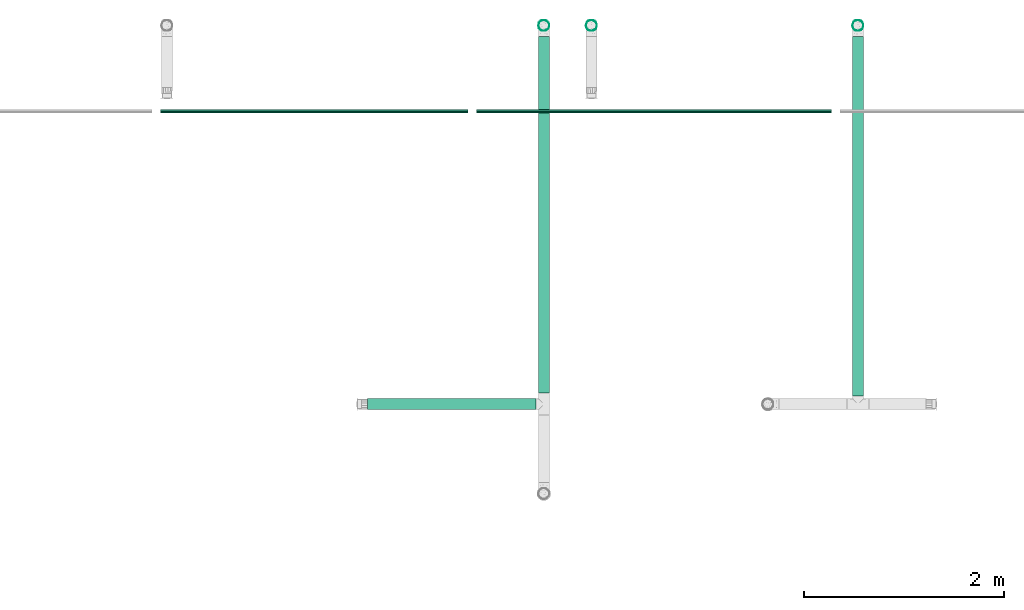
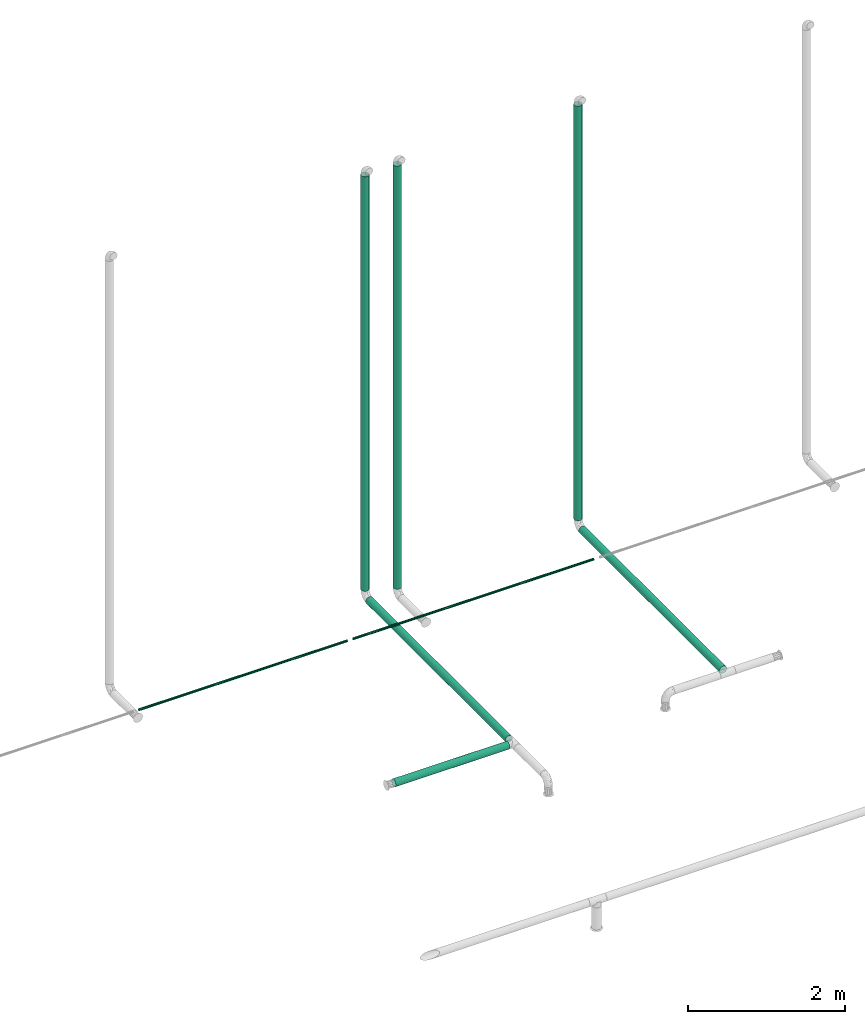
# One storey, part 18 of 123: 8 flow segments.
"""IFC2X3 building model written with IfcOpenShell, lengths in millimetres."""

from ifc_helpers import new_model, entity, si_unit, converted_unit, derived_unit, direction, frame, origin_with_axes, origin_2d_with_axis, place, context, subcontext, project, spatial, hollow_circle, extrude, source, transform, mapped, material, layer, layer_set, layer_usage, type_object, element, save


model = new_model("IFC2X3")

# Units and contexts
model_context = context("Model", 3, precision=1e-05, world=origin_with_axes(), true_north=direction((0.0, 1.0)))
body_context = subcontext(model_context, "Body", "Model", "MODEL_VIEW")
ifc_project = project(units=[si_unit("AREAUNIT", "SQUARE_METRE"), si_unit("VOLUMEUNIT", "CUBIC_METRE", prefix="DECI"), si_unit("TIMEUNIT", "SECOND"), si_unit("THERMODYNAMICTEMPERATUREUNIT", "DEGREE_CELSIUS"), si_unit("PRESSUREUNIT", "PASCAL"), si_unit("MASSUNIT", "GRAM", prefix="KILO"), si_unit("LENGTHUNIT", "METRE", prefix="MILLI"), si_unit("POWERUNIT", "WATT"), si_unit("ELECTRICCURRENTUNIT", "AMPERE"), si_unit("ELECTRICVOLTAGEUNIT", "VOLT"), derived_unit("VOLUMETRICFLOWRATEUNIT", [(si_unit("VOLUMEUNIT", "CUBIC_METRE", prefix="DECI"), 1), (si_unit("TIMEUNIT", "SECOND"), -1)]), derived_unit("LINEARVELOCITYUNIT", [(si_unit("LENGTHUNIT", "METRE"), 1), (si_unit("TIMEUNIT", "SECOND"), -1)]), derived_unit("MASSDENSITYUNIT", [(si_unit("MASSUNIT", "GRAM", prefix="KILO"), 1), (si_unit("VOLUMEUNIT", "CUBIC_METRE"), -1)]), converted_unit("PLANEANGLEUNIT", "DEGREE", entity("IfcRatioMeasure", 0.01745), si_unit("PLANEANGLEUNIT", "RADIAN"), dimensions=[0, 0, 0, 0, 0, 0, 0])], contexts=[model_context])

# Site, building, storey
site_placement = place(None, origin_with_axes())
site = spatial("IfcSite", under=ifc_project, at=site_placement, CompositionType="ELEMENT")
building_placement = place(site_placement, origin_with_axes())
building = spatial("IfcBuilding", under=site, at=building_placement, Name="mc-building", CompositionType="ELEMENT")
storey_placement = place(building_placement, origin_with_axes())
storey = spatial("IfcBuildingStorey", under=building, at=storey_placement, Name="1. Korrus", CompositionType="ELEMENT", Elevation=0.0)

# Flow segments
ifc_material_1 = material(Name="FZ1")
ifc_layer_1 = layer(ifc_material_1, 0.0)
ifc_layer_set_1 = layer_set([ifc_layer_1], Name="FZ1")
ifc_layer_usage_1 = layer_usage(ifc_layer_set_1, "AXIS1", "POSITIVE", 0.0)
duct_segment_type = type_object("IfcDuctSegmentType", PredefinedType="RIGIDSEGMENT")
shared_shape_1 = source(origin_with_axes(), body_context, "Body", "SweptSolid", [
    extrude(hollow_circle(Radius=55.0, WallThickness=2.0, at=origin_2d_with_axis()), frame((0.0, 0.0, 0.0), z_axis=(1.0, 0.0, 0.0), x_axis=(0.0, 1.0, 0.0)), (0.0, 0.0, 1.0), 3565.9),
])
flow_segment_1_placement = place(storey_placement, frame((29888.82784, 13553.57591, 2435.0), z_axis=(0.0, 0.0, 1.0), x_axis=(0.0, -1.0, 0.0)))
element("IfcFlowSegment", 1, at=flow_segment_1_placement, inside=storey, type_object=duct_segment_type, material=ifc_layer_usage_1, context=body_context, shape_type="MappedRepresentation", body=[
    mapped(shared_shape_1, transform((0.0, 0.0, 0.0), scale=1.0)),
])
shared_shape_2 = source(origin_with_axes(), body_context, "Body", "SweptSolid", [
    extrude(hollow_circle(Radius=55.0, WallThickness=2.0, at=origin_2d_with_axis()), frame((0.0, 0.0, 0.0), z_axis=(1.0, 0.0, 0.0), x_axis=(0.0, 1.0, 0.0)), (0.0, 0.0, 1.0), 6595.0),
])
flow_segment_2_placement = place(storey_placement, frame((30364.56773, 13663.57591, 2410.0), z_axis=(0.0, -1.0, 0.0), x_axis=(0.0, 0.0, 1.0)))
element("IfcFlowSegment", 2, at=flow_segment_2_placement, inside=storey, type_object=duct_segment_type, material=ifc_layer_usage_1, context=body_context, shape_type="MappedRepresentation", body=[
    mapped(shared_shape_2, transform((0.0, 0.0, 0.0), scale=1.0)),
])
ifc_material_2 = material(Name="Steel")
ifc_layer_2 = layer(ifc_material_2, 0.0)
ifc_layer_set_2 = layer_set([ifc_layer_2], Name="Steel")
ifc_layer_usage_2 = layer_usage(ifc_layer_set_2, "AXIS1", "POSITIVE", 0.0)
pipe_segment_type = type_object("IfcPipeSegmentType", PredefinedType="RIGIDSEGMENT")
shared_shape_3 = source(origin_with_axes(), body_context, "Body", "SweptSolid", [
    extrude(hollow_circle(Radius=17.5, WallThickness=2.0, at=origin_2d_with_axis()), frame((0.0, 0.0, 0.0), z_axis=(1.0, 0.0, 0.0), x_axis=(0.0, 1.0, 0.0)), (0.0, 0.0, 1.0), 3075.4),
])
flow_segment_3_placement = place(storey_placement, frame((26057.00462, 12807.91734, 2520.89768), z_axis=(0.0, 0.0, 1.0), x_axis=(1.0, 0.0, 0.0)))
element("IfcFlowSegment", 3, at=flow_segment_3_placement, inside=storey, type_object=pipe_segment_type, material=ifc_layer_usage_2, context=body_context, shape_type="MappedRepresentation", body=[
    mapped(shared_shape_3, transform((0.0, 0.0, 0.0), scale=1.0)),
])
shared_shape_4 = source(origin_with_axes(), body_context, "Body", "SweptSolid", [
    extrude(hollow_circle(Radius=17.5, WallThickness=2.0, at=origin_2d_with_axis()), frame((0.0, 0.0, 0.0), z_axis=(1.0, 0.0, 0.0), x_axis=(0.0, 1.0, 0.0)), (0.0, 0.0, 1.0), 3549.3),
])
flow_segment_4_placement = place(storey_placement, frame((29217.23953, 12807.91734, 2520.89768), z_axis=(0.0, 0.0, 1.0), x_axis=(1.0, 0.0, 0.0)))
element("IfcFlowSegment", 4, at=flow_segment_4_placement, inside=storey, type_object=pipe_segment_type, material=ifc_layer_usage_2, context=body_context, shape_type="MappedRepresentation", body=[
    mapped(shared_shape_4, transform((0.0, 0.0, 0.0), scale=1.0)),
])
shared_shape_5 = source(origin_with_axes(), body_context, "Body", "SweptSolid", [
    extrude(hollow_circle(Radius=55.0, WallThickness=2.0, at=origin_2d_with_axis()), frame((0.0, 0.0, 0.0), z_axis=(1.0, 0.0, 0.0), x_axis=(0.0, 1.0, 0.0)), (0.0, 0.0, 1.0), 3595.9),
])
flow_segment_5_placement = place(storey_placement, frame((33028.54629, 13553.57591, 2435.0), z_axis=(0.0, 0.0, 1.0), x_axis=(0.0, -1.0, 0.0)))
element("IfcFlowSegment", 5, at=flow_segment_5_placement, inside=storey, type_object=duct_segment_type, material=ifc_layer_usage_1, context=body_context, shape_type="MappedRepresentation", body=[
    mapped(shared_shape_5, transform((0.0, 0.0, 0.0), scale=1.0)),
])
shared_shape_6 = source(origin_with_axes(), body_context, "Body", "SweptSolid", [
    extrude(hollow_circle(Radius=55.0, WallThickness=2.0, at=origin_2d_with_axis()), frame((0.0, 0.0, 0.0), z_axis=(1.0, 0.0, 0.0), x_axis=(0.0, 1.0, 0.0)), (0.0, 0.0, 1.0), 6460.0),
])
for number, where, z_axis, x_axis in (
    (6, (33028.54629, 13663.57591, 2545.0), (0.0, -1.0, 0.0), (0.0, 0.0, 1.0)),
    (7, (29888.82784, 13663.57591, 2545.0), (0.0, -1.0, 0.0), (0.0, 0.0, 1.0)),
):
    element("IfcFlowSegment", number, at=place(storey_placement, frame(where, z_axis=z_axis, x_axis=x_axis)), inside=storey, type_object=duct_segment_type, material=ifc_layer_usage_1, context=body_context, shape_type="MappedRepresentation", body=[
        mapped(shared_shape_6, transform((0.0, 0.0, 0.0), scale=1.0)),
    ])
shared_shape_7 = source(origin_with_axes(), body_context, "Body", "SweptSolid", [
    extrude(hollow_circle(Radius=55.0, WallThickness=2.0, at=origin_2d_with_axis()), frame((0.0, 0.0, 0.0), z_axis=(1.0, 0.0, 0.0), x_axis=(0.0, 1.0, 0.0)), (0.0, 0.0, 1.0), 1681.2),
])
flow_segment_6_placement = place(storey_placement, frame((29808.82784, 9877.62755, 2435.0), z_axis=(0.0, 0.0, 1.0), x_axis=(-1.0, 0.0, 0.0)))
element("IfcFlowSegment", 8, at=flow_segment_6_placement, inside=storey, type_object=duct_segment_type, material=ifc_layer_usage_1, context=body_context, shape_type="MappedRepresentation", body=[
    mapped(shared_shape_7, transform((0.0, 0.0, 0.0), scale=1.0)),
])

save(model, "model.ifc")
